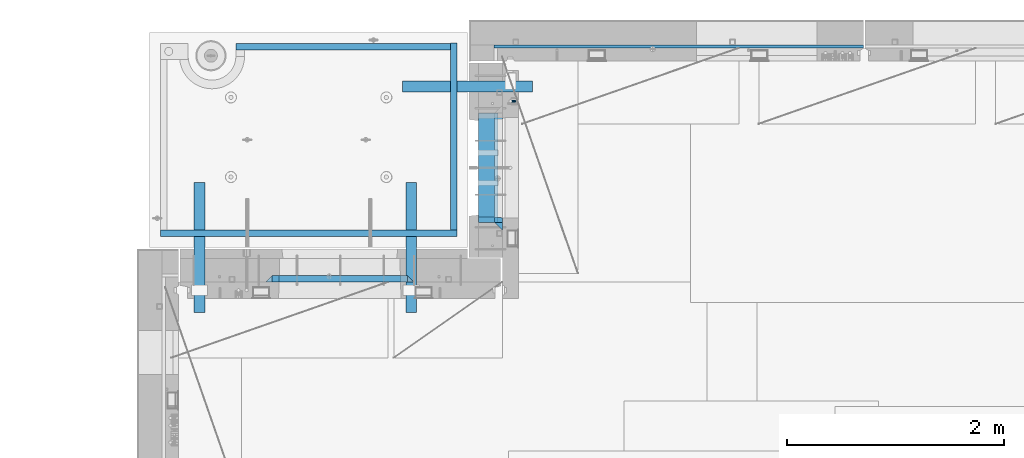
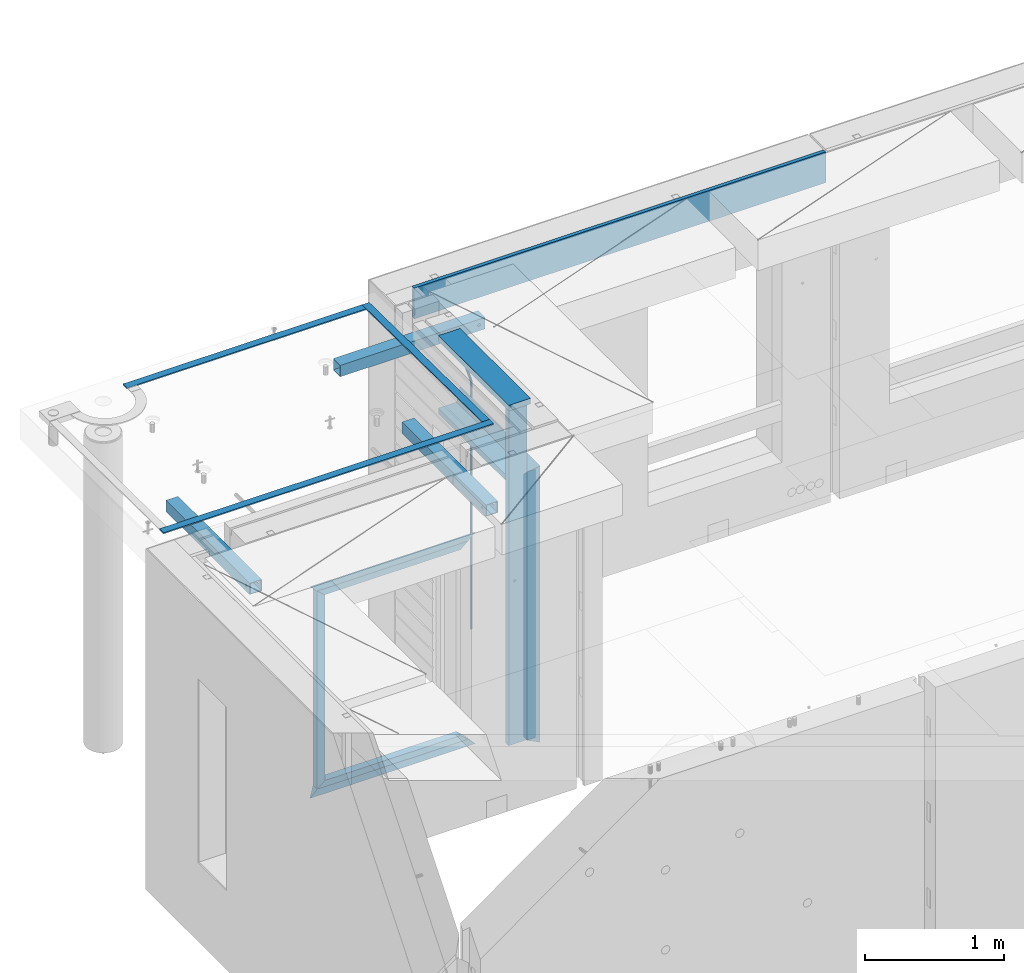
# One storey, part 111 of 341: 19 beams, 7 elements without a shape of their own.
"""IFC2X3 building model written with IfcOpenShell, lengths in millimetres."""

from ifc_helpers import new_model, si_unit, frame, origin_with_axes, place, context, subcontext, project, spatial, faceted_brep, material, type_object, element, aggregate, save


model = new_model("IFC2X3")

# Units and contexts
model_context = context("Model", 3, precision=1e-05, world=origin_with_axes())
body_context = subcontext(model_context, "Body", "Model", "MODEL_VIEW")
ifc_project = project(units=[si_unit("LENGTHUNIT", "METRE", prefix="MILLI"), si_unit("AREAUNIT", "SQUARE_METRE"), si_unit("VOLUMEUNIT", "CUBIC_METRE"), si_unit("MASSUNIT", "GRAM", prefix="KILO"), si_unit("TIMEUNIT", "SECOND"), si_unit("PLANEANGLEUNIT", "RADIAN"), si_unit("SOLIDANGLEUNIT", "STERADIAN"), si_unit("THERMODYNAMICTEMPERATUREUNIT", "DEGREE_CELSIUS"), si_unit("LUMINOUSINTENSITYUNIT", "LUMEN")], contexts=[model_context])

# Site, building, storey
site_placement = place(None, origin_with_axes())
site = spatial("IfcSite", under=ifc_project, at=site_placement, CompositionType="ELEMENT")
building_placement = place(site_placement, origin_with_axes())
building = spatial("IfcBuilding", under=site, at=building_placement, CompositionType="ELEMENT")
storey_placement = place(building_placement, origin_with_axes())
storey = spatial("IfcBuildingStorey", under=building, at=storey_placement, Name="5", CompositionType="ELEMENT", Elevation=0.0)

# Assembly, beams
assembly_1_placement = place(storey_placement, origin_with_axes())
assembly_1 = element("IfcElementAssembly", 1, at=assembly_1_placement, inside=storey, AssemblyPlace="NOTDEFINED", PredefinedType="REINFORCEMENT_UNIT")
ifc_material_1 = material(Name="CONCRETE/C25/30")
beam_type_1 = type_object("IfcBeamType", PredefinedType="NOTDEFINED")
beam_1_placement = place(assembly_1_placement, frame((10955.0, 22209.9998901814, 96140.0), z_axis=(0.0, 0.0, -1.0), x_axis=(0.0, -1.0, 0.0)))
beam_1 = element("IfcBeam", 2, at=beam_1_placement, type_object=beam_type_1, material=ifc_material_1, Name="SK", context=body_context, shape_type="Brep", body=[
    faceted_brep([(70.0000000000164, -35.0, 35.0), (70.0000000000164, 35.0, 35.0), (0.0, -35.0, -35.0), (1079.99961853027, -35.0, 35.0), (1079.99961853027, 35.0, 35.0), (1149.99961853027, -35.0, -35.0)], [[[0, 1, 2]], [[1, 0, 3, 4]], [[2, 1, 4, 5]], [[0, 2, 5, 3]], [[5, 4, 3]]]),
])
beam_2_placement = place(assembly_1_placement, frame((10955.0, 21095.0002716511, 96175.0), z_axis=(0.0, 1.0, 0.0), x_axis=(0.0, 0.0, -1.0)))
beam_2 = element("IfcBeam", 3, at=beam_2_placement, type_object=beam_type_1, material=ifc_material_1, Name="SK", context=body_context, shape_type="Brep", body=[
    faceted_brep([(2420.0, -35.0, 35.0), (2420.0, -35.0, -35.0), (2420.0, 35.0, 35.0), (70.0000000000164, -35.0, 35.0), (0.0, -35.0, -35.0), (70.0000000000164, 35.0, 35.0)], [[[0, 1, 2]], [[1, 0, 3, 4]], [[2, 1, 4, 5]], [[0, 2, 5, 3]], [[3, 5, 4]]]),
])
beam_type_2 = type_object("IfcBeamType", PredefinedType="NOTDEFINED")
beam_3_placement = place(assembly_1_placement, frame((10955.0, 21155.0002716511, 96105.0), z_axis=(0.0, 1.0, 0.0), x_axis=(0.0, 0.0, -1.0)))
beam_3 = element("IfcBeam", 4, at=beam_3_placement, type_object=beam_type_2, material=ifc_material_1, Name="SK", context=body_context, shape_type="Brep", body=[
    faceted_brep([(2350.0, -35.0, -25.0), (2350.0, 35.0, -25.0), (2350.0, 35.0, 20.6410256410309), (2350.0, -35.0, 18.8461538461561), (43.8461538461561, -35.0, 18.8461538461543), (0.0, -35.0, -25.0), (0.0, 35.0, -25.0), (45.6410256410309, 35.0, 20.6410256410254)], [[[0, 1, 2, 3]], [[0, 3, 4, 5]], [[1, 0, 5, 6]], [[2, 1, 6, 7]], [[3, 2, 7, 4]], [[7, 6, 5, 4]]]),
])
ifc_material_2 = material(Name="TIMBER")
beam_type_3 = type_object("IfcBeamType", Name="50X150", PredefinedType="NOTDEFINED")
beam_4_placement = place(assembly_1_placement, frame((10845.0, 22139.9998901814, 96080.0), z_axis=(0.0, 0.0, -1.0), x_axis=(0.0, -1.0, 0.0)))
beam_4 = element("IfcBeam", 5, at=beam_4_placement, type_object=beam_type_3, material=ifc_material_2, ObjectType="50X150", context=body_context, shape_type="Brep", body=[
    faceted_brep([(0.0, 75.0, -25.0), (1.81898940354586e-12, 75.0, 25.0), (1009.99961853027, 75.0, 25.0), (1009.99961853027, 75.0, -25.0), (1.81898940354586e-12, -75.0000000000009, 25.0), (1009.99961853027, -75.0, 25.0), (0.0, -75.0, -25.0), (1009.99961853027, -75.0, -25.0)], [[[0, 1, 2, 3]], [[1, 4, 5, 2]], [[4, 6, 7, 5]], [[6, 0, 3, 7]], [[5, 7, 3, 2]], [[6, 4, 1, 0]]]),
])
beam_5_placement = place(assembly_1_placement, frame((10845.0, 21155.0002716511, 96690.0), z_axis=(0.0, 1.0, 0.0), x_axis=(0.0, 0.0, -1.0)))
beam_5 = element("IfcBeam", 6, at=beam_5_placement, type_object=beam_type_3, material=ifc_material_2, ObjectType="50X150", context=body_context, shape_type="Brep", body=[
    faceted_brep([(0.0, 75.0, -25.0), (1.81898940354586e-12, 75.0, 25.0), (2930.0, 75.0, 25.0), (2930.0, 75.0, -25.0), (1.81898940354586e-12, -75.0000000000009, 25.0), (2930.0, -75.0, 25.0), (0.0, -75.0, -25.0), (2930.0, -75.0, -25.0)], [[[0, 1, 2, 3]], [[1, 4, 5, 2]], [[4, 6, 7, 5]], [[6, 0, 3, 7]], [[5, 7, 3, 2]], [[6, 4, 1, 0]]]),
])
ifc_material_3 = material()
beam_type_4 = type_object("IfcBeamType", Name="D20", PredefinedType="NOTDEFINED")
beam_6_placement = place(assembly_1_placement, frame((11065.0, 22249.9963332647, 96407.5), z_axis=(0.999999913638316, -0.000415599999849952, 0.0), x_axis=(0.0, 0.0, -1.0)))
beam_6 = element("IfcBeam", 7, at=beam_6_placement, type_object=beam_type_4, material=ifc_material_3, Name="JM20", ObjectType="D20", context=body_context, shape_type="Brep", body=[
    faceted_brep([(0.0, -10.0, 0.0), (-4.19531716033816e-08, -7.07106781186667, -7.07106781187031), (113.248091332178, -7.0710684840451, -7.0710678117357), (113.248091314759, -10.0000006713562, -2.51020537689328e-10), (0.0, 0.0, -10.0), (113.248091374131, -6.72178430249915e-07, -9.99999999986903), (4.196772351861e-08, 7.07106781186303, -7.07106781186667), (113.248091416113, 7.07106713968824, -7.07106781173934), (0.0, 10.0, 0.0), (113.248091433488, 9.99999932782521, 1.30967237055302e-10), (4.196772351861e-08, 7.07106781185939, 7.07106781185939), (113.248091416113, 7.0710671396846, 7.071067811994), (0.0, 0.0, 10.0), (113.248091374131, -6.72174792271107e-07, 10.0000000001273), (-4.19531716033816e-08, -7.07106781187031, 7.07106781185939), (113.248091332178, -7.0710684840451, 7.071067811994), (130.699843527167, -7.06993249763036, -4.33745683788584), (128.538066582521, -9.99900540317321, 2.39499413731755), (131.594536475241, 0.00119355250353692, -7.12624594330919), (130.698046432328, 7.07220300913468, -4.33773834422391), (128.535525107087, 10.0009944322555, 2.39459602660281), (126.373748162892, 7.07192152754578, 9.1270470011732), (125.479055214906, 0.000795477419160306, 11.9158361066184), (126.37554525779, -7.07021397921199, 9.12732850753673), (240.336258550378, -7.05529970173666, 30.8729495437874), (238.174481606227, -9.98437260450009, 37.6054005176375), (241.230951498423, 0.0158263482953771, 28.0841604381058), (240.334461455612, 7.0868358050102, 30.8726680369582), (238.171940130502, 10.0156272283348, 37.6050024077231), (236.010163186409, 7.08655432384694, 44.3374533824244), (235.115470238379, 0.0154282738185429, 47.1262424881097), (236.011960281176, -7.05558118289991, 44.3377348892536), (253.461915329972, -7.05444528127919, 32.9289287376414), (253.46191532613, -9.98337746617108, 39.9999965521893), (253.461915339081, 0.0166225284556276, 29.9999965443676), (253.461915348205, 7.08769034247234, 32.9289287273205), (253.461915352003, 10.0166225357716, 39.9999965370152), (253.461915348293, 7.08769035281148, 47.0710643509774), (253.461915339183, 0.0166225430875784, 49.999996544273), (253.46191533003, -7.05444527093641, 47.0710643613093), (2417.50000002384, -7.0544364694706, 32.9289287374122), (2417.5000000337, -9.98336865393321, 39.9999965507959), (2417.49999999997, 0.0166313408753922, 29.9999965456082), (2417.49999997609, 7.08769915426274, 32.9289287300708), (2417.4999999662, 10.0166313460668, 39.9999965404204), (2417.49999997608, 7.08769916160054, 47.0710643538114), (2417.49999999994, 0.0166313512581837, 49.9999965456154), (2417.50000002382, -7.05443646212916, 47.0710643611455)], [[[0, 1, 2, 3]], [[1, 4, 5, 2]], [[4, 6, 7, 5]], [[6, 8, 9, 7]], [[8, 10, 11, 9]], [[10, 12, 13, 11]], [[12, 14, 15, 13]], [[14, 0, 3, 15]], [[14, 12, 10, 8, 6, 4, 1, 0]], [[3, 2, 16, 17]], [[2, 5, 18, 16]], [[5, 7, 19, 18]], [[7, 9, 20, 19]], [[9, 11, 21, 20]], [[11, 13, 22, 21]], [[13, 15, 23, 22]], [[15, 3, 17, 23]], [[17, 16, 24, 25]], [[16, 18, 26, 24]], [[18, 19, 27, 26]], [[19, 20, 28, 27]], [[20, 21, 29, 28]], [[21, 22, 30, 29]], [[22, 23, 31, 30]], [[23, 17, 25, 31]], [[25, 24, 32, 33]], [[24, 26, 34, 32]], [[26, 27, 35, 34]], [[27, 28, 36, 35]], [[28, 29, 37, 36]], [[29, 30, 38, 37]], [[30, 31, 39, 38]], [[31, 25, 33, 39]], [[33, 32, 40, 41]], [[32, 34, 42, 40]], [[34, 35, 43, 42]], [[35, 36, 44, 43]], [[36, 37, 45, 44]], [[37, 38, 46, 45]], [[38, 39, 47, 46]], [[39, 33, 41, 47]], [[42, 43, 44, 45, 46, 47, 41, 40]]]),
])

# Assemblies, beams
assembly_2_placement = place(storey_placement, origin_with_axes())
assembly_2 = element("IfcElementAssembly", 8, at=assembly_2_placement, inside=storey, AssemblyPlace="NOTDEFINED", PredefinedType="REINFORCEMENT_UNIT")
assembly_3_placement = place(assembly_2_placement, origin_with_axes())
assembly_3 = element("IfcElementAssembly", 9, at=assembly_3_placement, AssemblyPlace="NOTDEFINED", PredefinedType="NOTDEFINED")
ifc_material_4 = material(Name="Undefined/350")
beam_type_5 = type_object("IfcBeamType", Name="100X100X5", PredefinedType="NOTDEFINED")
beam_7_placement = place(assembly_3_placement, frame((10069.9865573969, 22385.0401432011, 96555.0), z_axis=(0.0, 0.0, 1.0), x_axis=(0.999999999752625, -2.22429999942101e-05, 0.0)))
beam_7 = element("IfcBeam", 10, at=beam_7_placement, type_object=beam_type_5, material=ifc_material_4, ObjectType="100X100X5", context=body_context, shape_type="Brep", body=[
    faceted_brep([(1156.2510802317, 44.9999999999982, 10.8253175473074), (1156.25107855315, 50.0256005946221, 10.8253175473074), (1160.82639610046, 50.0256021227788, 6.25), (1160.82639777901, 44.9999999999982, 6.25), (1150.00108023171, 44.9999999999982, 12.5), (1150.00107855316, 50.0255985071226, 12.5), (1143.75108023171, 44.9999999999982, 10.8253175473074), (1143.75107855316, 50.0255964196231, 10.8253175473074), (1139.1757626844, 44.9999999999982, 6.25), (1139.17576100585, 50.0255948914664, 6.25), (1137.5010802317, 44.9999999999982, 0.0), (1137.50107855316, 50.0255943321226, 0.0), (1139.1757626844, 44.9999999999982, -6.25), (1139.17576100585, 50.0255948914664, -6.25), (1143.75108023171, 44.9999999999982, -10.8253175473074), (1143.75107855316, 50.0255964196231, -10.8253175473074), (1150.00108023171, 44.9999999999982, -12.5), (1150.00107855316, 50.0255985071226, -12.5), (1156.2510802317, 44.9999999999982, -10.8253175473074), (1156.25107855315, 50.0256005946221, -10.8253175473074), (1160.82639777901, 44.9999999999982, -6.25), (1160.82639610046, 50.0256021227788, -6.25), (1162.50108023171, 44.9999999999982, 0.0), (1162.50107855316, 50.0256026821226, 0.0), (1156.25111195316, -49.9743994042774, 10.8253175473074), (1156.25111029171, -44.9999999999991, 10.8253175473074), (1160.82642783901, -44.9999999999991, 6.25), (1160.82642950046, -49.9743978761207, 6.25), (1150.00111195316, -49.9744014917787, 12.5), (1150.00111029171, -44.9999999999991, 12.5), (1143.75111195316, -49.9744035792783, 10.8253175473074), (1143.75111029171, -44.9999999999991, 10.8253175473074), (1139.17579440585, -49.9744051074349, 6.25), (1139.1757927444, -44.9999999999991, 6.25), (1137.50111195316, -49.9744056667778, 0.0), (1137.50111029171, -44.9999999999991, 0.0), (1139.17579440585, -49.9744051074349, -6.25), (1139.1757927444, -44.9999999999991, -6.25), (1143.75111195316, -49.9744035792783, -10.8253175473074), (1143.75111029171, -44.9999999999991, -10.8253175473074), (1150.00111195316, -49.9744014917787, -12.5), (1150.00111029171, -44.9999999999991, -12.5), (1156.25111195316, -49.9743994042774, -10.8253175473074), (1156.25111029171, -44.9999999999991, -10.8253175473074), (1160.82642950046, -49.9743978761207, -6.25), (1160.82642783901, -44.9999999999991, -6.25), (1162.50111195316, -49.9743973167779, 0.0), (1162.50111029171, -44.9999999999991, 0.0), (1.81898940354586e-12, -50.0000000000009, -50.0), (1.81898940354586e-12, 49.9999999999991, -50.0), (1200.00449189278, 49.9999999999982, -50.0), (1200.00449189278, -50.0000000000009, -50.0), (1.81898940354586e-12, 49.9999999999991, 50.0), (1.81898940354586e-12, -50.0000000000009, 50.0), (1200.00449189278, -50.0000000000009, 50.0), (1200.00449189278, 49.9999999999982, 50.0), (0.0, 44.9999999999991, 45.0), (1.81898940354586e-12, -45.0000000000009, 45.0), (1.81898940354586e-12, -45.0000000000009, -45.0), (0.0, 44.9999999999991, -45.0), (1200.00449189278, 44.9999999999982, -45.0), (1200.00449189278, 44.9999999999982, 45.0), (1200.00449189278, -45.0000000000009, 45.0), (1200.00449189278, -45.0000000000009, -45.0)], [[[0, 1, 2, 3]], [[4, 5, 1, 0]], [[6, 7, 5, 4]], [[8, 9, 7, 6]], [[10, 11, 9, 8]], [[12, 13, 11, 10]], [[14, 15, 13, 12]], [[16, 17, 15, 14]], [[18, 19, 17, 16]], [[20, 21, 19, 18]], [[22, 23, 21, 20]], [[3, 2, 23, 22]], [[24, 25, 26, 27]], [[28, 29, 25, 24]], [[30, 31, 29, 28]], [[32, 33, 31, 30]], [[34, 35, 33, 32]], [[36, 37, 35, 34]], [[38, 39, 37, 36]], [[40, 41, 39, 38]], [[42, 43, 41, 40]], [[44, 45, 43, 42]], [[46, 47, 45, 44]], [[27, 26, 47, 46]], [[48, 49, 50, 51]], [[52, 53, 54, 55]], [[49, 52, 55, 50], [1, 5, 7, 9, 11, 13, 15, 17, 19, 21, 23, 2]], [[48, 53, 52, 49], [56, 57, 58, 59]], [[56, 59, 60, 61], [18, 16, 14, 12, 10, 8, 6, 4, 0, 3, 22, 20]], [[57, 56, 61, 62]], [[58, 57, 62, 63], [25, 29, 31, 33, 35, 37, 39, 41, 43, 45, 47, 26]], [[59, 58, 63, 60]], [[54, 51, 50, 55], [62, 61, 60, 63]], [[53, 48, 51, 54], [42, 40, 38, 36, 34, 32, 30, 28, 24, 27, 46, 44]]]),
])
aggregate(assembly_3, [beam_7])
assembly_4_placement = place(assembly_2_placement, origin_with_axes())
assembly_4 = element("IfcElementAssembly", 11, at=assembly_4_placement, AssemblyPlace="NOTDEFINED", PredefinedType="NOTDEFINED")
beam_8_placement = place(assembly_4_placement, frame((10150.0001432011, 21500.0034426031, 96555.0), z_axis=(0.0, 0.0, 1.0), x_axis=(-2.2242999997242e-05, -0.999999999752625, 0.0)))
beam_8 = element("IfcBeam", 12, at=beam_8_placement, type_object=beam_type_5, material=ifc_material_4, ObjectType="100X100X5", context=body_context, shape_type="Brep", body=[
    faceted_brep([(1143.75108023171, 44.9999999999982, -10.8253175473074), (1143.75107855316, 50.0255964196231, -10.8253175473074), (1139.17576100585, 50.0255948914664, -6.25), (1139.1757626844, 44.9999999999982, -6.25), (1150.00108023171, 44.9999999999982, -12.5), (1150.00107855316, 50.0255985071226, -12.5), (1156.2510802317, 44.9999999999982, -10.8253175473074), (1156.25107855315, 50.0256005946221, -10.8253175473074), (1160.82639777901, 44.9999999999982, -6.25), (1160.82639610046, 50.0256021227788, -6.25), (1162.50108023171, 44.9999999999982, 0.0), (1162.50107855316, 50.0256026821226, 0.0), (1160.82639777901, 44.9999999999982, 6.25), (1160.82639610046, 50.0256021227788, 6.25), (1156.2510802317, 44.9999999999982, 10.8253175473074), (1156.25107855315, 50.0256005946221, 10.8253175473074), (1150.00108023171, 44.9999999999982, 12.5), (1150.00107855316, 50.0255985071226, 12.5), (1143.75108023171, 44.9999999999982, 10.8253175473074), (1143.75107855316, 50.0255964196231, 10.8253175473074), (1139.1757626844, 44.9999999999982, 6.25), (1139.17576100585, 50.0255948914664, 6.25), (1137.5010802317, 44.9999999999982, 0.0), (1137.50107855316, 50.0255943321226, 0.0), (1143.75111195316, -49.9744035792783, -10.8253175473074), (1143.75111029171, -44.9999999999991, -10.8253175473074), (1139.1757927444, -44.9999999999991, -6.25), (1139.17579440585, -49.9744051074349, -6.25), (1150.00111195316, -49.9744014917787, -12.5), (1150.00111029171, -44.9999999999991, -12.5), (1156.25111195316, -49.9743994042774, -10.8253175473074), (1156.25111029171, -44.9999999999991, -10.8253175473074), (1160.82642950046, -49.9743978761207, -6.25), (1160.82642783901, -44.9999999999991, -6.25), (1162.50111195316, -49.9743973167779, 0.0), (1162.50111029171, -44.9999999999991, 0.0), (1160.82642950046, -49.9743978761207, 6.25), (1160.82642783901, -44.9999999999991, 6.25), (1156.25111195316, -49.9743994042774, 10.8253175473074), (1156.25111029171, -44.9999999999991, 10.8253175473074), (1150.00111195316, -49.9744014917787, 12.5), (1150.00111029171, -44.9999999999991, 12.5), (1143.75111195316, -49.9744035792783, 10.8253175473074), (1143.75111029171, -44.9999999999991, 10.8253175473074), (1139.17579440585, -49.9744051074349, 6.25), (1139.1757927444, -44.9999999999991, 6.25), (1137.50111195316, -49.9744056667778, 0.0), (1137.50111029171, -44.9999999999991, 0.0), (1.81898940354586e-12, -50.0000000000009, -50.0), (1.81898940354586e-12, 49.9999999999991, -50.0), (1200.00449189278, 49.9999999999982, -50.0), (1200.00449189278, -50.0000000000009, -50.0), (1.81898940354586e-12, 49.9999999999991, 50.0), (1.81898940354586e-12, -50.0000000000009, 50.0), (1200.00449189278, -50.0000000000009, 50.0), (1200.00449189278, 49.9999999999982, 50.0), (0.0, 44.9999999999991, 45.0), (1.81898940354586e-12, -45.0000000000009, 45.0), (1.81898940354586e-12, -45.0000000000009, -45.0), (0.0, 44.9999999999991, -45.0), (1200.00449189278, 44.9999999999982, -45.0), (1200.00449189278, 44.9999999999982, 45.0), (1200.00449189278, -45.0000000000009, 45.0), (1200.00449189278, -45.0000000000009, -45.0)], [[[0, 1, 2, 3]], [[4, 5, 1, 0]], [[6, 7, 5, 4]], [[8, 9, 7, 6]], [[10, 11, 9, 8]], [[12, 13, 11, 10]], [[14, 15, 13, 12]], [[16, 17, 15, 14]], [[18, 19, 17, 16]], [[20, 21, 19, 18]], [[22, 23, 21, 20]], [[3, 2, 23, 22]], [[24, 25, 26, 27]], [[28, 29, 25, 24]], [[30, 31, 29, 28]], [[32, 33, 31, 30]], [[34, 35, 33, 32]], [[36, 37, 35, 34]], [[38, 39, 37, 36]], [[40, 41, 39, 38]], [[42, 43, 41, 40]], [[44, 45, 43, 42]], [[46, 47, 45, 44]], [[27, 26, 47, 46]], [[48, 49, 50, 51]], [[52, 53, 54, 55]], [[49, 52, 55, 50], [15, 17, 19, 21, 23, 2, 1, 5, 7, 9, 11, 13]], [[48, 53, 52, 49], [56, 57, 58, 59]], [[56, 59, 60, 61], [6, 4, 0, 3, 22, 20, 18, 16, 14, 12, 10, 8]], [[57, 56, 61, 62]], [[58, 57, 62, 63], [39, 41, 43, 45, 47, 26, 25, 29, 31, 33, 35, 37]], [[59, 58, 63, 60]], [[54, 51, 50, 55], [62, 61, 60, 63]], [[53, 48, 51, 54], [30, 28, 24, 27, 46, 44, 42, 40, 38, 36, 34, 32]]]),
])
aggregate(assembly_4, [beam_8])
assembly_5_placement = place(assembly_2_placement, origin_with_axes())
assembly_5 = element("IfcElementAssembly", 13, at=assembly_5_placement, AssemblyPlace="NOTDEFINED", PredefinedType="NOTDEFINED")
beam_9_placement = place(assembly_5_placement, frame((8195.00014320107, 21500.0034426031, 96555.0), z_axis=(0.0, 0.0, 1.0), x_axis=(-2.2242999997242e-05, -0.999999999752625, 0.0)))
beam_9 = element("IfcBeam", 14, at=beam_9_placement, type_object=beam_type_5, material=ifc_material_4, ObjectType="100X100X5", context=body_context, shape_type="Brep", body=[
    faceted_brep([(1143.75108023171, 44.9999999999982, -10.8253175473074), (1143.75107855316, 50.0255964196231, -10.8253175473074), (1139.17576100585, 50.0255948914664, -6.25), (1139.1757626844, 44.9999999999982, -6.25), (1150.00108023171, 44.9999999999982, -12.5), (1150.00107855316, 50.0255985071226, -12.5), (1156.2510802317, 44.9999999999982, -10.8253175473074), (1156.25107855315, 50.0256005946221, -10.8253175473074), (1160.82639777901, 44.9999999999982, -6.25), (1160.82639610046, 50.0256021227788, -6.25), (1162.50108023171, 44.9999999999982, 0.0), (1162.50107855316, 50.0256026821226, 0.0), (1160.82639777901, 44.9999999999982, 6.25), (1160.82639610046, 50.0256021227788, 6.25), (1156.2510802317, 44.9999999999982, 10.8253175473074), (1156.25107855315, 50.0256005946221, 10.8253175473074), (1150.00108023171, 44.9999999999982, 12.5), (1150.00107855316, 50.0255985071226, 12.5), (1143.75108023171, 44.9999999999982, 10.8253175473074), (1143.75107855316, 50.0255964196231, 10.8253175473074), (1139.1757626844, 44.9999999999982, 6.25), (1139.17576100585, 50.0255948914664, 6.25), (1137.5010802317, 44.9999999999982, 0.0), (1137.50107855316, 50.0255943321226, 0.0), (1143.75111195316, -49.9744035792783, -10.8253175473074), (1143.75111029171, -44.9999999999991, -10.8253175473074), (1139.1757927444, -44.9999999999991, -6.25), (1139.17579440585, -49.9744051074349, -6.25), (1150.00111195316, -49.9744014917787, -12.5), (1150.00111029171, -44.9999999999991, -12.5), (1156.25111195316, -49.9743994042774, -10.8253175473074), (1156.25111029171, -44.9999999999991, -10.8253175473074), (1160.82642950046, -49.9743978761207, -6.25), (1160.82642783901, -44.9999999999991, -6.25), (1162.50111195316, -49.9743973167779, 0.0), (1162.50111029171, -44.9999999999991, 0.0), (1160.82642950046, -49.9743978761207, 6.25), (1160.82642783901, -44.9999999999991, 6.25), (1156.25111195316, -49.9743994042774, 10.8253175473074), (1156.25111029171, -44.9999999999991, 10.8253175473074), (1150.00111195316, -49.9744014917787, 12.5), (1150.00111029171, -44.9999999999991, 12.5), (1143.75111195316, -49.9744035792783, 10.8253175473074), (1143.75111029171, -44.9999999999991, 10.8253175473074), (1139.17579440585, -49.9744051074349, 6.25), (1139.1757927444, -44.9999999999991, 6.25), (1137.50111195316, -49.9744056667778, 0.0), (1137.50111029171, -44.9999999999991, 0.0), (1.81898940354586e-12, -50.0000000000009, -50.0), (1.81898940354586e-12, 49.9999999999991, -50.0), (1200.00449189278, 49.9999999999982, -50.0), (1200.00449189278, -50.0000000000009, -50.0), (1.81898940354586e-12, 49.9999999999991, 50.0), (1.81898940354586e-12, -50.0000000000009, 50.0), (1200.00449189278, -50.0000000000009, 50.0), (1200.00449189278, 49.9999999999982, 50.0), (0.0, 44.9999999999991, 45.0), (1.81898940354586e-12, -45.0000000000009, 45.0), (1.81898940354586e-12, -45.0000000000009, -45.0), (0.0, 44.9999999999991, -45.0), (1200.00449189278, 44.9999999999982, -45.0), (1200.00449189278, 44.9999999999982, 45.0), (1200.00449189278, -45.0000000000009, 45.0), (1200.00449189278, -45.0000000000009, -45.0)], [[[0, 1, 2, 3]], [[4, 5, 1, 0]], [[6, 7, 5, 4]], [[8, 9, 7, 6]], [[10, 11, 9, 8]], [[12, 13, 11, 10]], [[14, 15, 13, 12]], [[16, 17, 15, 14]], [[18, 19, 17, 16]], [[20, 21, 19, 18]], [[22, 23, 21, 20]], [[3, 2, 23, 22]], [[24, 25, 26, 27]], [[28, 29, 25, 24]], [[30, 31, 29, 28]], [[32, 33, 31, 30]], [[34, 35, 33, 32]], [[36, 37, 35, 34]], [[38, 39, 37, 36]], [[40, 41, 39, 38]], [[42, 43, 41, 40]], [[44, 45, 43, 42]], [[46, 47, 45, 44]], [[27, 26, 47, 46]], [[48, 49, 50, 51]], [[52, 53, 54, 55]], [[49, 52, 55, 50], [15, 17, 19, 21, 23, 2, 1, 5, 7, 9, 11, 13]], [[48, 53, 52, 49], [56, 57, 58, 59]], [[56, 59, 60, 61], [6, 4, 0, 3, 22, 20, 18, 16, 14, 12, 10, 8]], [[57, 56, 61, 62]], [[58, 57, 62, 63], [39, 41, 43, 45, 47, 26, 25, 29, 31, 33, 35, 37]], [[59, 58, 63, 60]], [[54, 51, 50, 55], [62, 61, 60, 63]], [[53, 48, 51, 54], [30, 28, 24, 27, 46, 44, 42, 40, 38, 36, 34, 32]]]),
])
aggregate(assembly_5, [beam_9])
ifc_material_5 = material(Name="CONCRETE/Concrete_Undefined")
beam_type_6 = type_object("IfcBeamType", PredefinedType="NOTDEFINED")
beam_10_placement = place(assembly_2_placement, frame((8529.99466999203, 22755.2837502302, 96704.830444231), z_axis=(-8.94119999996021e-05, 2.00000067707701e-09, 0.999999996002747), x_axis=(0.999999995749149, -2.25209999937896e-05, 8.94119999812374e-05)))
beam_10 = element("IfcBeam", 15, at=beam_10_placement, type_object=beam_type_6, material=ifc_material_5, context=body_context, shape_type="Brep", body=[
    faceted_brep([(2.5465851649642e-11, 29.9999999999982, -4.99999999998545), (-2.91038304567337e-11, 29.9999999999982, 5.0), (1980.00575712919, 30.0, 5.0), (1980.00575712919, 30.0, -5.0), (-2.5465851649642e-11, -30.0000000000018, 5.0), (1980.00575712919, -30.0, 5.0), (2.72848410531878e-11, -30.0000000000018, -4.99999999998545), (1980.00575712919, -30.0, -5.00000000001455)], [[[0, 1, 2, 3]], [[1, 4, 5, 2]], [[4, 6, 7, 5]], [[6, 0, 3, 7]], [[5, 7, 3, 2]], [[6, 4, 1, 0]]]),
])
beam_11_placement = place(assembly_2_placement, frame((10540.0586106742, 21059.9845873458, 96725.6637899649), z_axis=(-4.06999999693443e-07, 0.0121707750045615, 0.999925933374879), x_axis=(-3.34759999933477e-05, 0.999925932814682, -0.0121707749977451)))
beam_11 = element("IfcBeam", 16, at=beam_11_placement, type_object=beam_type_6, material=ifc_material_5, context=body_context, shape_type="Brep", body=[
    faceted_brep([(2.5465851649642e-11, 29.9999999999982, -4.99999999998545), (-2.91038304567337e-11, 29.9999999999982, 5.0), (1725.44357525616, 30.0000000000036, 5.00000000001455), (1725.4435752563, 30.0, -4.9999999999709), (-2.5465851649642e-11, -30.0000000000018, 5.0), (1725.44357525616, -29.9999999999964, 5.0000000000291), (2.72848410531878e-11, -30.0000000000018, -4.99999999998545), (1725.4435752563, -30.0, -4.99999999998545)], [[[0, 1, 2, 3]], [[1, 4, 5, 2]], [[4, 6, 7, 5]], [[6, 0, 3, 7]], [[5, 7, 3, 2]], [[6, 4, 1, 0]]]),
])
beam_12_placement = place(assembly_2_placement, frame((7834.99819277187, 21029.998155674, 96725.2788443216), z_axis=(-0.000140627000015522, 4.00000135459113e-09, 0.999999990112023), x_axis=(0.999999989763253, -2.64109999939869e-05, 0.000140626999967189)))
beam_12 = element("IfcBeam", 17, at=beam_12_placement, type_object=beam_type_6, material=ifc_material_5, context=body_context, shape_type="Brep", body=[
    faceted_brep([(2.5465851649642e-11, 29.9999999999982, -4.99999999998545), (-2.91038304567337e-11, 29.9999999999982, 5.0), (2735.00002544224, 30.0, 5.0), (2735.00002544224, 30.0, -5.0), (-2.5465851649642e-11, -30.0000000000018, 5.0), (2735.00002544224, -29.9999999999964, 5.0), (2.72848410531878e-11, -30.0000000000018, -4.99999999998545), (2735.00002544224, -29.9999999999964, -5.0)], [[[0, 1, 2, 3]], [[1, 4, 5, 2]], [[4, 6, 7, 5]], [[6, 0, 3, 7]], [[5, 7, 3, 2]], [[6, 4, 1, 0]]]),
])
aggregate(assembly_2, [assembly_3, assembly_4, assembly_5, beam_10, beam_11, beam_12])

# Assembly, beams
assembly_6_placement = place(storey_placement, origin_with_axes())
assembly_6 = element("IfcElementAssembly", 18, at=assembly_6_placement, inside=storey, AssemblyPlace="NOTDEFINED", PredefinedType="REINFORCEMENT_UNIT")
beam_type_7 = type_object("IfcBeamType", PredefinedType="NOTDEFINED")
beam_13_placement = place(assembly_6_placement, frame((10174.9997107317, 20609.9951872276, 96145.0), z_axis=(0.0, 0.0, -1.0), x_axis=(-1.0, 3.00000001838171e-08, 0.0)))
beam_13 = element("IfcBeam", 19, at=beam_13_placement, type_object=beam_type_7, material=ifc_material_1, Name="SK", context=body_context, shape_type="Brep", body=[
    faceted_brep([(60.0000000000073, 30.0, 30.0), (0.0, -30.0, -30.0), (60.0000000000073, -30.0, 30.0), (1309.99847412109, 30.0, 30.0), (1369.99847412109, -30.0, -30.0), (1309.99847412109, -30.0, 30.0)], [[[0, 1, 2]], [[1, 0, 3, 4]], [[2, 1, 4, 5]], [[0, 2, 5, 3]], [[3, 5, 4]]]),
])
beam_14_placement = place(assembly_6_placement, frame((10114.9997107317, 20609.9951872276, 96085.0), z_axis=(0.0, 0.0, -1.0), x_axis=(-1.0, 3.00000001838171e-08, 0.0)))
beam_14 = element("IfcBeam", 20, at=beam_14_placement, type_object=beam_type_7, material=ifc_material_1, Name="SK", context=body_context, shape_type="Brep", body=[
    faceted_brep([(65.6741497967687, 29.999999998452, 26.2921283848846), (0.0, 30.0, -30.0), (0.0, -30.0, -30.0), (64.0525281752307, -29.999999998452, 24.9021669953072), (64.0525281752307, -29.999999998452, 24.0540540541406), (65.6741497967687, 29.999999998452, 25.6756756756804), (1185.94442006696, -29.999999998452, 24.0540540541406), (1184.32279844542, 29.999999998452, 25.6756756756804), (1184.32279844542, 29.999999998452, 26.2934362810629), (1249.99847412109, 29.999999998452, -30.0), (1249.99847412109, -29.999999998452, -30.0), (1185.94442006696, -29.999999998452, 24.9034748915001)], [[[0, 1, 2, 3]], [[4, 5, 0, 3]], [[6, 7, 5, 4]], [[1, 0, 5, 7, 8, 9]], [[2, 1, 9, 10]], [[6, 4, 3, 2, 10, 11]], [[7, 6, 11, 8]], [[9, 8, 11, 10]]]),
])
beam_15_placement = place(assembly_6_placement, frame((8805.00123661063, 20609.9951872276, 94350.0), z_axis=(0.0, 0.0, 1.0), x_axis=(1.0, 0.0, 0.0)))
beam_15 = element("IfcBeam", 21, at=beam_15_placement, type_object=beam_type_7, material=ifc_material_1, Name="SK", context=body_context, shape_type="Brep", body=[
    faceted_brep([(1309.99847412109, 30.0, 30.0), (1309.99847412109, -30.0, 30.0), (1369.99847412109, -30.0, -30.0), (60.0000000000073, 30.0, 30.0), (60.0000000000073, -30.0, 30.0), (0.0, -30.0, -30.0)], [[[0, 1, 2]], [[3, 4, 1, 0]], [[4, 5, 2, 1]], [[5, 3, 0, 2]], [[3, 5, 4]]]),
])
beam_16_placement = place(assembly_6_placement, frame((8865.00123661063, 20609.9951872276, 94410.0), z_axis=(0.0, 0.0, 1.0), x_axis=(1.0, 0.0, 0.0)))
beam_16 = element("IfcBeam", 22, at=beam_16_placement, type_object=beam_type_7, material=ifc_material_1, Name="SK", context=body_context, shape_type="Brep", body=[
    faceted_brep([(1184.32432432433, 29.999999998452, 26.2921283848846), (1185.94594594586, -29.999999998452, 24.9021669952926), (1249.99847412109, -29.999999998452, -30.0), (1249.99847412109, 29.999999998452, -30.0), (1184.32432432432, 29.9999988381387, 25.6756756756804), (1185.94594588314, -29.9999988381387, 24.0540541168593), (65.6756756756768, 30.0, 25.6756756756804), (64.0540540540533, -30.0, 24.0540540540533), (65.6756756756768, 30.0, 26.293436281092), (64.0540540540533, -30.0, 24.9034748914419), (0.0, -30.0, -30.0), (0.0, 30.0, -30.0)], [[[0, 1, 2, 3]], [[4, 5, 1, 0]], [[5, 4, 6, 7]], [[7, 6, 8, 9]], [[2, 1, 5, 7, 9, 10]], [[10, 11, 3, 2]], [[6, 4, 0, 3, 11, 8]], [[10, 9, 8, 11]]]),
])
beam_type_8 = type_object("IfcBeamType", PredefinedType="NOTDEFINED")
beam_17_placement = place(assembly_6_placement, frame((8900.00123661063, 20609.9951872276, 96115.0), z_axis=(1.0, 0.0, 0.0), x_axis=(0.0, 0.0, -1.0)))
beam_17 = element("IfcBeam", 23, at=beam_17_placement, type_object=beam_type_8, material=ifc_material_1, Name="SK", context=body_context, shape_type="Brep", body=[
    faceted_brep([(0.0, -30.0, -35.0), (54.9034748914273, -30.0, 29.0540540540533), (56.2934362811066, 30.0, 30.6756756756768), (0.0, 30.0, -35.0), (1678.70656371891, 30.0, 30.6756756756768), (1735.0, 30.0, -35.0), (1735.0, -30.0, -35.0), (1680.09652510857, -30.0, 29.0540540540533)], [[[0, 1, 2, 3]], [[3, 2, 4, 5]], [[5, 6, 0, 3]], [[1, 0, 6, 7]], [[2, 1, 7, 4]], [[6, 5, 4, 7]]]),
])
aggregate(assembly_6, [beam_13, beam_14, beam_17, beam_15, beam_16])

# Assembly, beam
assembly_7_placement = place(storey_placement, origin_with_axes())
assembly_7 = element("IfcElementAssembly", 24, at=assembly_7_placement, inside=storey, AssemblyPlace="NOTDEFINED", PredefinedType="REINFORCEMENT_UNIT")
beam_type_9 = type_object("IfcBeamType", Name="270X30", PredefinedType="NOTDEFINED")
beam_18_placement = place(assembly_7_placement, frame((14325.0, 22755.0, 96605.0), z_axis=(0.0, 0.0, 1.0), x_axis=(-1.0, 3.00000001838171e-08, 0.0)))
beam_18 = element("IfcBeam", 25, at=beam_18_placement, type_object=beam_type_9, material=ifc_material_1, ObjectType="270X30", context=body_context, shape_type="Brep", body=[
    faceted_brep([(0.0, 15.0, -135.0), (0.0, 15.0, 135.0), (3410.00000000003, 15.0, 135.0), (3410.00000000003, 15.0, -135.0), (0.0, -15.0, 135.0), (3410.00000000003, -15.0, 135.0), (0.0, -15.0, -135.0), (3410.00000000003, -15.0, -135.0)], [[[0, 1, 2, 3]], [[1, 4, 5, 2]], [[4, 6, 7, 5]], [[6, 0, 3, 7]], [[5, 7, 3, 2]], [[6, 4, 1, 0]]]),
])
aggregate(assembly_7, [beam_18])

# Beam
beam_type_10 = type_object("IfcBeamType", PredefinedType="NOTDEFINED")
beam_19_placement = place(assembly_1_placement, frame((10860.0, 21129.9999618525, 96715.0), z_axis=(0.0, 0.0, 1.0), x_axis=(0.0, 1.0, 0.0)))
beam_19 = element("IfcBeam", 26, at=beam_19_placement, type_object=beam_type_10, material=ifc_material_2, context=body_context, shape_type="Brep", body=[
    faceted_brep([(0.0, 90.0, -25.0), (0.0, 90.0, 25.0), (1009.99983857082, 90.0, 25.0), (1009.99983857082, 90.0, -25.0), (0.0, -90.0, 25.0), (1009.99983857082, -90.0, 25.0), (0.0, -90.0, -25.0), (1009.99983857082, -90.0, -25.0)], [[[0, 1, 2, 3]], [[1, 4, 5, 2]], [[4, 6, 7, 5]], [[6, 0, 3, 7]], [[5, 7, 3, 2]], [[6, 4, 1, 0]]]),
])

aggregate(assembly_1, [beam_6, beam_1, beam_2, beam_3, beam_4, beam_5, beam_19])

save(model, "model.ifc")
